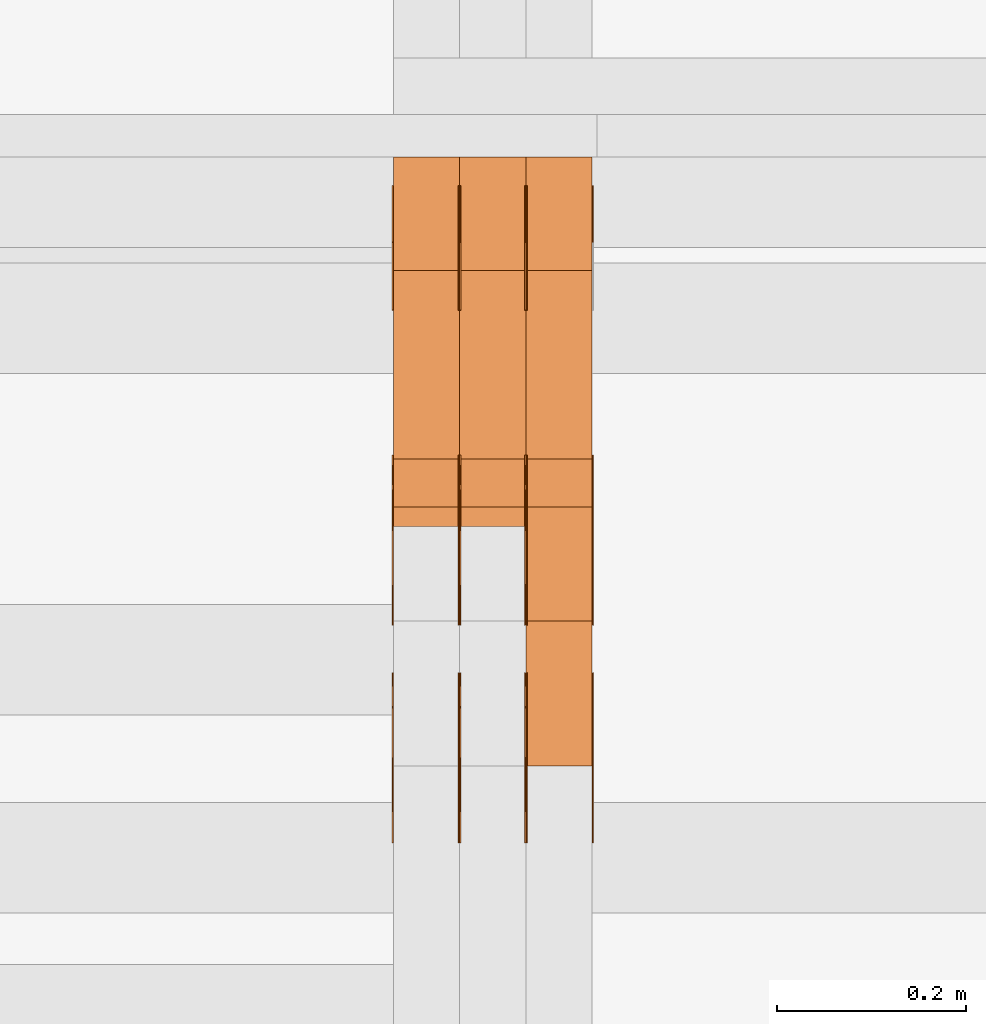
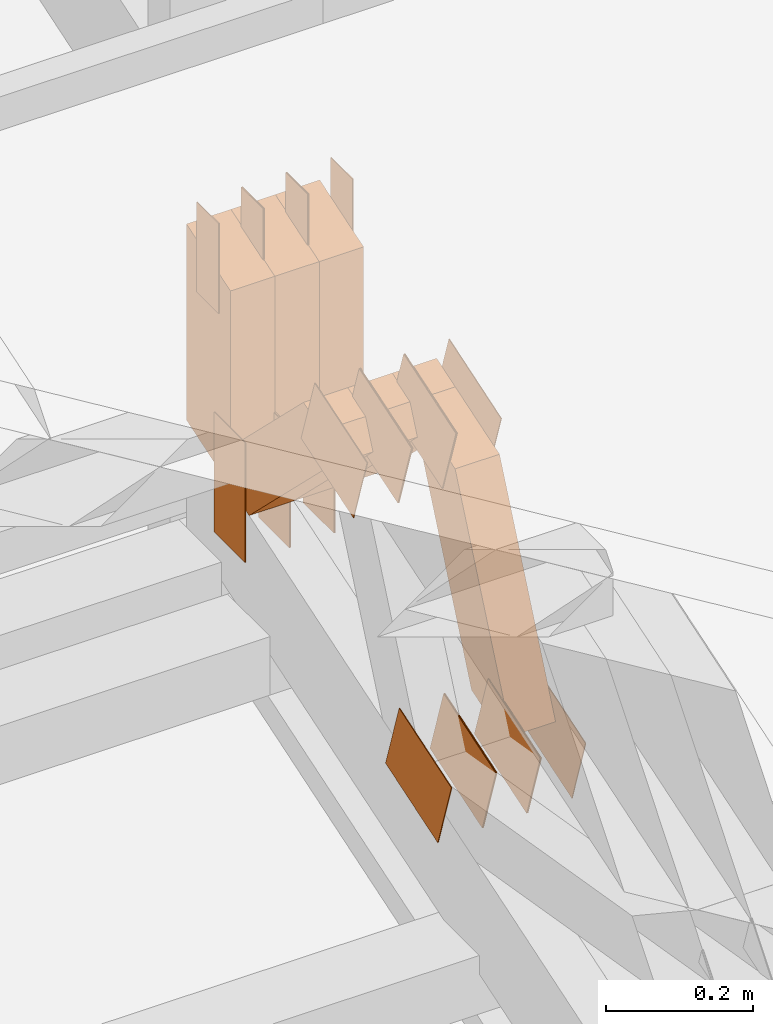
# One storey, part 78 of 385: 30 proxies.
"""IFC2X3 building model written with IfcOpenShell, lengths in millimetres."""

from ifc_helpers import new_model, entity, si_unit, converted_unit, derived_unit, direction, frame, frame_2d, origin, origin_2d_with_axis, place, context, subcontext, project, spatial, polyline, rectangle, outline, extrude, source, transform, mapped, material, type_object, type_shapes, element, save


model = new_model("IFC2X3")

# Units and contexts
model_context = context("Model", 3, precision=0.01, world=origin(), true_north=direction((6.12303176911189e-17, 1.0)))
body_context = subcontext(model_context, "Body", "Model", "MODEL_VIEW")
ifc_project = project(units=[si_unit("LENGTHUNIT", "METRE", prefix="MILLI"), si_unit("AREAUNIT", "SQUARE_METRE"), si_unit("VOLUMEUNIT", "CUBIC_METRE"), converted_unit("PLANEANGLEUNIT", "DEGREE", entity("IfcRatioMeasure", 0.0174532925199433), si_unit("PLANEANGLEUNIT", "RADIAN"), dimensions=[0, 0, 0, 0, 0, 0, 0]), si_unit("MASSUNIT", "GRAM", prefix="KILO"), derived_unit("MASSDENSITYUNIT", [(si_unit("MASSUNIT", "GRAM", prefix="KILO"), 1), (si_unit("LENGTHUNIT", "METRE"), -3)]), si_unit("TIMEUNIT", "SECOND"), si_unit("FREQUENCYUNIT", "HERTZ"), si_unit("THERMODYNAMICTEMPERATUREUNIT", "DEGREE_CELSIUS"), derived_unit("THERMALTRANSMITTANCEUNIT", [(si_unit("MASSUNIT", "GRAM", prefix="KILO"), 1), (si_unit("THERMODYNAMICTEMPERATUREUNIT", "KELVIN"), -1), (si_unit("TIMEUNIT", "SECOND"), -3)]), derived_unit("VOLUMETRICFLOWRATEUNIT", [(si_unit("LENGTHUNIT", "METRE"), 3), (si_unit("TIMEUNIT", "SECOND"), -1)]), si_unit("ELECTRICCURRENTUNIT", "AMPERE"), si_unit("ELECTRICVOLTAGEUNIT", "VOLT"), si_unit("POWERUNIT", "WATT"), si_unit("FORCEUNIT", "NEWTON", prefix="KILO"), si_unit("ILLUMINANCEUNIT", "LUX"), si_unit("LUMINOUSFLUXUNIT", "LUMEN"), si_unit("LUMINOUSINTENSITYUNIT", "CANDELA"), derived_unit("USERDEFINED", [(si_unit("MASSUNIT", "GRAM", prefix="KILO"), -1), (si_unit("LENGTHUNIT", "METRE"), -2), (si_unit("TIMEUNIT", "SECOND"), 3), (si_unit("LUMINOUSFLUXUNIT", "LUMEN"), 1)]), derived_unit("LINEARVELOCITYUNIT", [(si_unit("LENGTHUNIT", "METRE"), 1), (si_unit("TIMEUNIT", "SECOND"), -1)]), si_unit("PRESSUREUNIT", "PASCAL"), derived_unit("USERDEFINED", [(si_unit("LENGTHUNIT", "METRE"), -2), (si_unit("MASSUNIT", "GRAM", prefix="KILO"), 1), (si_unit("TIMEUNIT", "SECOND"), -2)])], contexts=[model_context])

# Site, building, storey
site_placement = place(None, origin())
site = spatial("IfcSite", under=ifc_project, at=site_placement, CompositionType="ELEMENT")
building_placement = place(site_placement, origin())
building = spatial("IfcBuilding", under=site, at=building_placement, CompositionType="ELEMENT")
storey_placement = place(building_placement, origin())
storey = spatial("IfcBuildingStorey", under=building, at=storey_placement, Name="Default", CompositionType="ELEMENT", Elevation=0.0)

# Proxies
ifc_material_1 = material(Name="IfcSurfaceStyle #71355")
building_element_proxy_type_1 = type_object("IfcBuildingElementProxyType", PredefinedType="NOTDEFINED", material=ifc_material_1)
shared_shape_1 = source(origin(), body_context, "Body", "SweptSolid", [
    extrude(rectangle(XDim=200.0, YDim=84.0, at=frame_2d((0.0, -7.105427357601e-15), x_axis=(1.0, 0.0))), frame((100.0, 42.0, 0.0), z_axis=(0.0, 0.0, 1.0), x_axis=(-1.0, 0.0, 0.0)), (0.0, 0.0, 1.0), 1.3),
])
type_shapes(building_element_proxy_type_1, [shared_shape_1])
proxy_1_placement = place(building_placement, frame((3315.0, 13702.0, 3651.4150390625), z_axis=(-1.0, 0.0, 0.0), x_axis=(0.0, 0.0, -1.0)))
element("IfcBuildingElementProxy", 1, at=proxy_1_placement, inside=storey, type_object=building_element_proxy_type_1, material=ifc_material_1, context=body_context, shape_type="MappedRepresentation", body=[
    mapped(shared_shape_1, transform((0.0, 0.0, 0.0), scale=1.0)),
])
ifc_material_2 = material(Name="IfcSurfaceStyle #71298")
building_element_proxy_type_2 = type_object("IfcBuildingElementProxyType", PredefinedType="NOTDEFINED", material=ifc_material_2)
shared_shape_2 = source(origin(), body_context, "Body", "SweptSolid", [
    extrude(rectangle(XDim=200.0, YDim=84.0, at=frame_2d((0.0, -7.105427357601e-15), x_axis=(1.0, 0.0))), frame((100.0, 42.0, 0.0), z_axis=(0.0, 0.0, 1.0), x_axis=(-1.0, 0.0, 0.0)), (0.0, 0.0, 1.0), 1.3),
])
type_shapes(building_element_proxy_type_2, [shared_shape_2])
proxy_2_placement = place(building_placement, frame((3316.29999999999, 13702.0, 3651.4150390625), z_axis=(-1.0, 0.0, 0.0), x_axis=(0.0, 0.0, -1.0)))
element("IfcBuildingElementProxy", 2, at=proxy_2_placement, inside=storey, type_object=building_element_proxy_type_2, material=ifc_material_2, context=body_context, shape_type="MappedRepresentation", body=[
    mapped(shared_shape_2, transform((0.0, 0.0, 0.0), scale=1.0)),
])
ifc_material_3 = material(Name="IfcSurfaceStyle #71241")
building_element_proxy_type_3 = type_object("IfcBuildingElementProxyType", PredefinedType="NOTDEFINED", material=ifc_material_3)
shared_shape_3 = source(origin(), body_context, "Body", "SweptSolid", [
    extrude(rectangle(XDim=200.0, YDim=84.0, at=frame_2d((0.0, -7.105427357601e-15), x_axis=(1.0, 0.0))), frame((100.0, 42.0, 0.0), z_axis=(0.0, 0.0, 1.0), x_axis=(-1.0, 0.0, 0.0)), (0.0, 0.0, 1.0), 1.29999999999998),
])
type_shapes(building_element_proxy_type_3, [shared_shape_3])
proxy_3_placement = place(building_placement, frame((3245.0, 13702.0, 3651.4150390625), z_axis=(-1.0, 0.0, 0.0), x_axis=(0.0, 0.0, -1.0)))
element("IfcBuildingElementProxy", 3, at=proxy_3_placement, inside=storey, type_object=building_element_proxy_type_3, material=ifc_material_3, context=body_context, shape_type="MappedRepresentation", body=[
    mapped(shared_shape_3, transform((0.0, 0.0, 0.0), scale=1.0)),
])
ifc_material_4 = material(Name="IfcSurfaceStyle #71184")
building_element_proxy_type_4 = type_object("IfcBuildingElementProxyType", PredefinedType="NOTDEFINED", material=ifc_material_4)
shared_shape_4 = source(origin(), body_context, "Body", "SweptSolid", [
    extrude(rectangle(XDim=200.0, YDim=84.0, at=frame_2d((0.0, -7.105427357601e-15), x_axis=(1.0, 0.0))), frame((100.0, 42.0, 0.0), z_axis=(0.0, 0.0, 1.0), x_axis=(-1.0, 0.0, 0.0)), (0.0, 0.0, 1.0), 1.29999999999998),
])
type_shapes(building_element_proxy_type_4, [shared_shape_4])
proxy_4_placement = place(building_placement, frame((3246.29999999999, 13702.0, 3651.4150390625), z_axis=(-1.0, 0.0, 0.0), x_axis=(0.0, 0.0, -1.0)))
element("IfcBuildingElementProxy", 4, at=proxy_4_placement, inside=storey, type_object=building_element_proxy_type_4, material=ifc_material_4, context=body_context, shape_type="MappedRepresentation", body=[
    mapped(shared_shape_4, transform((0.0, 0.0, 0.0), scale=1.0)),
])
ifc_material_5 = material(Name="IfcSurfaceStyle #71127")
building_element_proxy_type_5 = type_object("IfcBuildingElementProxyType", PredefinedType="NOTDEFINED", material=ifc_material_5)
shared_shape_5 = source(origin(), body_context, "Body", "SweptSolid", [
    extrude(rectangle(XDim=200.0, YDim=84.0, at=frame_2d((0.0, -7.105427357601e-15), x_axis=(1.0, 0.0))), frame((100.0, 42.0, 0.0), z_axis=(0.0, 0.0, 1.0), x_axis=(-1.0, 0.0, 0.0)), (0.0, 0.0, 1.0), 1.29999999999999),
])
type_shapes(building_element_proxy_type_5, [shared_shape_5])
proxy_5_placement = place(building_placement, frame((3175.0, 13702.0, 3651.4150390625), z_axis=(-1.0, 0.0, 0.0), x_axis=(0.0, 0.0, -1.0)))
element("IfcBuildingElementProxy", 5, at=proxy_5_placement, inside=storey, type_object=building_element_proxy_type_5, material=ifc_material_5, context=body_context, shape_type="MappedRepresentation", body=[
    mapped(shared_shape_5, transform((0.0, 0.0, 0.0), scale=1.0)),
])
ifc_material_6 = material(Name="IfcSurfaceStyle #71070")
building_element_proxy_type_6 = type_object("IfcBuildingElementProxyType", PredefinedType="NOTDEFINED", material=ifc_material_6)
shared_shape_6 = source(origin(), body_context, "Body", "SweptSolid", [
    extrude(outline(polyline([(-75.0003398116828, -59.9998507501386), (75.0003249421766, -59.9998507501386), (75.0003398116837, 59.9998507501387), (-75.0003249421775, 59.9998507501387), (-75.0003398116828, -59.9998507501386)])), frame((75.0003398116837, 60.0000773549637, 0.0), z_axis=(0.0, 0.0, 1.0), x_axis=(-1.0, 0.0, 0.0)), (0.0, 0.0, 1.0), 1.3),
])
type_shapes(building_element_proxy_type_6, [shared_shape_6])
proxy_6_placement = place(building_placement, frame((3386.29999999999, 13054.73046875, 3417.8388671875), z_axis=(-1.0, 0.0, 0.0), x_axis=(0.0, 0.951056516295124, 0.309016994375039)))
element("IfcBuildingElementProxy", 6, at=proxy_6_placement, inside=storey, type_object=building_element_proxy_type_6, material=ifc_material_6, context=body_context, shape_type="MappedRepresentation", body=[
    mapped(shared_shape_6, transform((0.0, 0.0, 0.0), scale=1.0)),
])
ifc_material_7 = material(Name="IfcSurfaceStyle #71013")
building_element_proxy_type_7 = type_object("IfcBuildingElementProxyType", PredefinedType="NOTDEFINED", material=ifc_material_7)
shared_shape_7 = source(origin(), body_context, "Body", "SweptSolid", [
    extrude(outline(polyline([(-75.0003398116828, -59.9998507501386), (75.0003249421766, -59.9998507501386), (75.0003398116837, 59.9998507501387), (-75.0003249421775, 59.9998507501387), (-75.0003398116828, -59.9998507501386)])), frame((75.0003398116837, 60.0000773549637, 0.0), z_axis=(0.0, 0.0, 1.0), x_axis=(-1.0, 0.0, 0.0)), (0.0, 0.0, 1.0), 1.3),
])
type_shapes(building_element_proxy_type_7, [shared_shape_7])
proxy_7_placement = place(building_placement, frame((3315.0, 13054.73046875, 3417.8388671875), z_axis=(-1.0, 0.0, 0.0), x_axis=(0.0, 0.951056516295124, 0.309016994375039)))
element("IfcBuildingElementProxy", 7, at=proxy_7_placement, inside=storey, type_object=building_element_proxy_type_7, material=ifc_material_7, context=body_context, shape_type="MappedRepresentation", body=[
    mapped(shared_shape_7, transform((0.0, 0.0, 0.0), scale=1.0)),
])
ifc_material_8 = material(Name="IfcSurfaceStyle #70956")
building_element_proxy_type_8 = type_object("IfcBuildingElementProxyType", PredefinedType="NOTDEFINED", material=ifc_material_8)
shared_shape_8 = source(origin(), body_context, "Body", "SweptSolid", [
    extrude(outline(polyline([(-75.0003398116828, -59.9998507501386), (75.0003249421766, -59.9998507501386), (75.0003398116837, 59.9998507501387), (-75.0003249421775, 59.9998507501387), (-75.0003398116828, -59.9998507501386)])), frame((75.0003398116837, 60.0000773549637, 0.0), z_axis=(0.0, 0.0, 1.0), x_axis=(-1.0, 0.0, 0.0)), (0.0, 0.0, 1.0), 1.3),
])
type_shapes(building_element_proxy_type_8, [shared_shape_8])
proxy_8_placement = place(building_placement, frame((3316.29999999999, 13054.73046875, 3417.8388671875), z_axis=(-1.0, 0.0, 0.0), x_axis=(0.0, 0.951056516295124, 0.309016994375039)))
element("IfcBuildingElementProxy", 8, at=proxy_8_placement, inside=storey, type_object=building_element_proxy_type_8, material=ifc_material_8, context=body_context, shape_type="MappedRepresentation", body=[
    mapped(shared_shape_8, transform((0.0, 0.0, 0.0), scale=1.0)),
])
ifc_material_9 = material(Name="IfcSurfaceStyle #70899")
building_element_proxy_type_9 = type_object("IfcBuildingElementProxyType", PredefinedType="NOTDEFINED", material=ifc_material_9)
shared_shape_9 = source(origin(), body_context, "Body", "SweptSolid", [
    extrude(outline(polyline([(-75.0003398116828, -59.9998507501386), (75.0003249421766, -59.9998507501386), (75.0003398116837, 59.9998507501387), (-75.0003249421775, 59.9998507501387), (-75.0003398116828, -59.9998507501386)])), frame((75.0003398116837, 60.0000773549637, 0.0), z_axis=(0.0, 0.0, 1.0), x_axis=(-1.0, 0.0, 0.0)), (0.0, 0.0, 1.0), 1.29999999999999),
])
type_shapes(building_element_proxy_type_9, [shared_shape_9])
proxy_9_placement = place(building_placement, frame((3245.0, 13054.73046875, 3417.8388671875), z_axis=(-1.0, 0.0, 0.0), x_axis=(0.0, 0.951056516295124, 0.309016994375039)))
element("IfcBuildingElementProxy", 9, at=proxy_9_placement, inside=storey, type_object=building_element_proxy_type_9, material=ifc_material_9, context=body_context, shape_type="MappedRepresentation", body=[
    mapped(shared_shape_9, transform((0.0, 0.0, 0.0), scale=1.0)),
])
ifc_material_10 = material(Name="IfcSurfaceStyle #70842")
building_element_proxy_type_10 = type_object("IfcBuildingElementProxyType", PredefinedType="NOTDEFINED", material=ifc_material_10)
shared_shape_10 = source(origin(), body_context, "Body", "SweptSolid", [
    extrude(outline(polyline([(-75.0003398116828, -59.9998507501386), (75.0003249421766, -59.9998507501386), (75.0003398116837, 59.9998507501387), (-75.0003249421775, 59.9998507501387), (-75.0003398116828, -59.9998507501386)])), frame((75.0003398116837, 60.0000773549637, 0.0), z_axis=(0.0, 0.0, 1.0), x_axis=(-1.0, 0.0, 0.0)), (0.0, 0.0, 1.0), 1.29999999999999),
])
type_shapes(building_element_proxy_type_10, [shared_shape_10])
proxy_10_placement = place(building_placement, frame((3246.29999999999, 13054.73046875, 3417.8388671875), z_axis=(-1.0, 0.0, 0.0), x_axis=(0.0, 0.951056516295124, 0.309016994375039)))
element("IfcBuildingElementProxy", 10, at=proxy_10_placement, inside=storey, type_object=building_element_proxy_type_10, material=ifc_material_10, context=body_context, shape_type="MappedRepresentation", body=[
    mapped(shared_shape_10, transform((0.0, 0.0, 0.0), scale=1.0)),
])
ifc_material_11 = material(Name="IfcSurfaceStyle #70785")
building_element_proxy_type_11 = type_object("IfcBuildingElementProxyType", PredefinedType="NOTDEFINED", material=ifc_material_11)
shared_shape_11 = source(origin(), body_context, "Body", "SweptSolid", [
    extrude(outline(polyline([(-75.0003398116828, -59.9998507501386), (75.0003249421766, -59.9998507501386), (75.0003398116837, 59.9998507501387), (-75.0003249421775, 59.9998507501387), (-75.0003398116828, -59.9998507501386)])), frame((75.0003398116837, 60.0000773549637, 0.0), z_axis=(0.0, 0.0, 1.0), x_axis=(-1.0, 0.0, 0.0)), (0.0, 0.0, 1.0), 1.29999999999999),
])
type_shapes(building_element_proxy_type_11, [shared_shape_11])
proxy_11_placement = place(building_placement, frame((3175.0, 13054.73046875, 3417.8388671875), z_axis=(-1.0, 0.0, 0.0), x_axis=(0.0, 0.951056516295124, 0.309016994375039)))
element("IfcBuildingElementProxy", 11, at=proxy_11_placement, inside=storey, type_object=building_element_proxy_type_11, material=ifc_material_11, context=body_context, shape_type="MappedRepresentation", body=[
    mapped(shared_shape_11, transform((0.0, 0.0, 0.0), scale=1.0)),
])
ifc_material_12 = material(Name="IfcSurfaceStyle #63204")
building_element_proxy_type_12 = type_object("IfcBuildingElementProxyType", PredefinedType="NOTDEFINED", material=ifc_material_12)
shared_shape_12 = source(origin(), body_context, "Body", "SweptSolid", [
    extrude(outline(polyline([(-74.999875428623, -60.0000016373506), (74.9998605591059, -60.0000016373506), (74.9998754286239, 60.0000016373506), (-74.9998605591068, 60.0000016373506), (-74.999875428623, -60.0000016373506)])), frame((75.0002691827262, 60.0000190504561, 0.0), z_axis=(0.0, 0.0, 1.0), x_axis=(-1.0, 0.0, 0.0)), (0.0, 0.0, 1.0), 1.3),
])
type_shapes(building_element_proxy_type_12, [shared_shape_12])
proxy_12_placement = place(building_placement, frame((3386.29999999999, 13285.0865109705, 3819.37496637467), z_axis=(-1.0, 0.0, 0.0), x_axis=(0.0, 0.951056516295154, 0.309016994374948)))
element("IfcBuildingElementProxy", 12, at=proxy_12_placement, inside=storey, type_object=building_element_proxy_type_12, material=ifc_material_12, context=body_context, shape_type="MappedRepresentation", body=[
    mapped(shared_shape_12, transform((0.0, 0.0, 0.0), scale=1.0)),
])
ifc_material_13 = material(Name="IfcSurfaceStyle #63147")
building_element_proxy_type_13 = type_object("IfcBuildingElementProxyType", PredefinedType="NOTDEFINED", material=ifc_material_13)
shared_shape_13 = source(origin(), body_context, "Body", "SweptSolid", [
    extrude(outline(polyline([(-74.999875428623, -60.0000016373506), (74.9998605591059, -60.0000016373506), (74.9998754286239, 60.0000016373506), (-74.9998605591068, 60.0000016373506), (-74.999875428623, -60.0000016373506)])), frame((75.0002691827262, 60.0000190504561, 0.0), z_axis=(0.0, 0.0, 1.0), x_axis=(-1.0, 0.0, 0.0)), (0.0, 0.0, 1.0), 1.3),
])
type_shapes(building_element_proxy_type_13, [shared_shape_13])
proxy_13_placement = place(building_placement, frame((3315.0, 13285.0865109705, 3819.37496637467), z_axis=(-1.0, 0.0, 0.0), x_axis=(0.0, 0.951056516295154, 0.309016994374948)))
element("IfcBuildingElementProxy", 13, at=proxy_13_placement, inside=storey, type_object=building_element_proxy_type_13, material=ifc_material_13, context=body_context, shape_type="MappedRepresentation", body=[
    mapped(shared_shape_13, transform((0.0, 0.0, 0.0), scale=1.0)),
])
ifc_material_14 = material(Name="IfcSurfaceStyle #63090")
building_element_proxy_type_14 = type_object("IfcBuildingElementProxyType", PredefinedType="NOTDEFINED", material=ifc_material_14)
shared_shape_14 = source(origin(), body_context, "Body", "SweptSolid", [
    extrude(outline(polyline([(-74.999875428623, -60.0000016373506), (74.9998605591059, -60.0000016373506), (74.9998754286239, 60.0000016373506), (-74.9998605591068, 60.0000016373506), (-74.999875428623, -60.0000016373506)])), frame((75.0002691827262, 60.0000190504561, 0.0), z_axis=(0.0, 0.0, 1.0), x_axis=(-1.0, 0.0, 0.0)), (0.0, 0.0, 1.0), 1.3),
])
type_shapes(building_element_proxy_type_14, [shared_shape_14])
proxy_14_placement = place(building_placement, frame((3316.29999999999, 13285.0865109705, 3819.37496637467), z_axis=(-1.0, 0.0, 0.0), x_axis=(0.0, 0.951056516295154, 0.309016994374948)))
element("IfcBuildingElementProxy", 14, at=proxy_14_placement, inside=storey, type_object=building_element_proxy_type_14, material=ifc_material_14, context=body_context, shape_type="MappedRepresentation", body=[
    mapped(shared_shape_14, transform((0.0, 0.0, 0.0), scale=1.0)),
])
ifc_material_15 = material(Name="IfcSurfaceStyle #63033")
building_element_proxy_type_15 = type_object("IfcBuildingElementProxyType", PredefinedType="NOTDEFINED", material=ifc_material_15)
shared_shape_15 = source(origin(), body_context, "Body", "SweptSolid", [
    extrude(outline(polyline([(-74.999875428623, -60.0000016373506), (74.9998605591059, -60.0000016373506), (74.9998754286239, 60.0000016373506), (-74.9998605591068, 60.0000016373506), (-74.999875428623, -60.0000016373506)])), frame((75.0002691827262, 60.0000190504561, 0.0), z_axis=(0.0, 0.0, 1.0), x_axis=(-1.0, 0.0, 0.0)), (0.0, 0.0, 1.0), 1.29999999999999),
])
type_shapes(building_element_proxy_type_15, [shared_shape_15])
proxy_15_placement = place(building_placement, frame((3245.0, 13285.0865109705, 3819.37496637467), z_axis=(-1.0, 0.0, 0.0), x_axis=(0.0, 0.951056516295154, 0.309016994374948)))
element("IfcBuildingElementProxy", 15, at=proxy_15_placement, inside=storey, type_object=building_element_proxy_type_15, material=ifc_material_15, context=body_context, shape_type="MappedRepresentation", body=[
    mapped(shared_shape_15, transform((0.0, 0.0, 0.0), scale=1.0)),
])
ifc_material_16 = material(Name="IfcSurfaceStyle #62976")
building_element_proxy_type_16 = type_object("IfcBuildingElementProxyType", PredefinedType="NOTDEFINED", material=ifc_material_16)
shared_shape_16 = source(origin(), body_context, "Body", "SweptSolid", [
    extrude(outline(polyline([(-74.999875428623, -60.0000016373506), (74.9998605591059, -60.0000016373506), (74.9998754286239, 60.0000016373506), (-74.9998605591068, 60.0000016373506), (-74.999875428623, -60.0000016373506)])), frame((75.0002691827262, 60.0000190504561, 0.0), z_axis=(0.0, 0.0, 1.0), x_axis=(-1.0, 0.0, 0.0)), (0.0, 0.0, 1.0), 1.29999999999999),
])
type_shapes(building_element_proxy_type_16, [shared_shape_16])
proxy_16_placement = place(building_placement, frame((3246.29999999999, 13285.0865109705, 3819.37496637467), z_axis=(-1.0, 0.0, 0.0), x_axis=(0.0, 0.951056516295154, 0.309016994374948)))
element("IfcBuildingElementProxy", 16, at=proxy_16_placement, inside=storey, type_object=building_element_proxy_type_16, material=ifc_material_16, context=body_context, shape_type="MappedRepresentation", body=[
    mapped(shared_shape_16, transform((0.0, 0.0, 0.0), scale=1.0)),
])
ifc_material_17 = material(Name="IfcSurfaceStyle #62919")
building_element_proxy_type_17 = type_object("IfcBuildingElementProxyType", PredefinedType="NOTDEFINED", material=ifc_material_17)
shared_shape_17 = source(origin(), body_context, "Body", "SweptSolid", [
    extrude(outline(polyline([(-74.999875428623, -60.0000016373506), (74.9998605591059, -60.0000016373506), (74.9998754286239, 60.0000016373506), (-74.9998605591068, 60.0000016373506), (-74.999875428623, -60.0000016373506)])), frame((75.0002691827262, 60.0000190504561, 0.0), z_axis=(0.0, 0.0, 1.0), x_axis=(-1.0, 0.0, 0.0)), (0.0, 0.0, 1.0), 1.29999999999999),
])
type_shapes(building_element_proxy_type_17, [shared_shape_17])
proxy_17_placement = place(building_placement, frame((3175.0, 13285.0865109705, 3819.37496637467), z_axis=(-1.0, 0.0, 0.0), x_axis=(0.0, 0.951056516295154, 0.309016994374948)))
element("IfcBuildingElementProxy", 17, at=proxy_17_placement, inside=storey, type_object=building_element_proxy_type_17, material=ifc_material_17, context=body_context, shape_type="MappedRepresentation", body=[
    mapped(shared_shape_17, transform((0.0, 0.0, 0.0), scale=1.0)),
])
ifc_material_18 = material(Name="IfcSurfaceStyle #62520")
building_element_proxy_type_18 = type_object("IfcBuildingElementProxyType", PredefinedType="NOTDEFINED", material=ifc_material_18)
shared_shape_18 = source(origin(), body_context, "Body", "SweptSolid", [
    extrude(rectangle(XDim=150.0, YDim=60.0, at=origin_2d_with_axis()), frame((75.0000705696166, 30.0, 0.0), z_axis=(0.0, 0.0, 1.0), x_axis=(-1.0, 0.0, 0.0)), (0.0, 0.0, 1.0), 1.3),
])
type_shapes(building_element_proxy_type_18, [shared_shape_18])
proxy_18_placement = place(building_placement, frame((3386.29999999999, 13750.0, 3972.59919166337), z_axis=(-1.0, 0.0, 0.0), x_axis=(0.0, 0.0, -1.0)))
element("IfcBuildingElementProxy", 18, at=proxy_18_placement, inside=storey, type_object=building_element_proxy_type_18, material=ifc_material_18, context=body_context, shape_type="MappedRepresentation", body=[
    mapped(shared_shape_18, transform((0.0, 0.0, 0.0), scale=1.0)),
])
ifc_material_19 = material(Name="IfcSurfaceStyle #62463")
building_element_proxy_type_19 = type_object("IfcBuildingElementProxyType", PredefinedType="NOTDEFINED", material=ifc_material_19)
shared_shape_19 = source(origin(), body_context, "Body", "SweptSolid", [
    extrude(rectangle(XDim=150.0, YDim=60.0, at=origin_2d_with_axis()), frame((75.0000705696166, 30.0, 0.0), z_axis=(0.0, 0.0, 1.0), x_axis=(-1.0, 0.0, 0.0)), (0.0, 0.0, 1.0), 1.3),
])
type_shapes(building_element_proxy_type_19, [shared_shape_19])
proxy_19_placement = place(building_placement, frame((3315.0, 13750.0, 3972.59919166337), z_axis=(-1.0, 0.0, 0.0), x_axis=(0.0, 0.0, -1.0)))
element("IfcBuildingElementProxy", 19, at=proxy_19_placement, inside=storey, type_object=building_element_proxy_type_19, material=ifc_material_19, context=body_context, shape_type="MappedRepresentation", body=[
    mapped(shared_shape_19, transform((0.0, 0.0, 0.0), scale=1.0)),
])
ifc_material_20 = material(Name="IfcSurfaceStyle #62406")
building_element_proxy_type_20 = type_object("IfcBuildingElementProxyType", PredefinedType="NOTDEFINED", material=ifc_material_20)
shared_shape_20 = source(origin(), body_context, "Body", "SweptSolid", [
    extrude(rectangle(XDim=150.0, YDim=60.0, at=origin_2d_with_axis()), frame((75.0000705696166, 30.0, 0.0), z_axis=(0.0, 0.0, 1.0), x_axis=(-1.0, 0.0, 0.0)), (0.0, 0.0, 1.0), 1.3),
])
type_shapes(building_element_proxy_type_20, [shared_shape_20])
proxy_20_placement = place(building_placement, frame((3316.29999999999, 13750.0, 3972.59919166337), z_axis=(-1.0, 0.0, 0.0), x_axis=(0.0, 0.0, -1.0)))
element("IfcBuildingElementProxy", 20, at=proxy_20_placement, inside=storey, type_object=building_element_proxy_type_20, material=ifc_material_20, context=body_context, shape_type="MappedRepresentation", body=[
    mapped(shared_shape_20, transform((0.0, 0.0, 0.0), scale=1.0)),
])
ifc_material_21 = material(Name="IfcSurfaceStyle #62349")
building_element_proxy_type_21 = type_object("IfcBuildingElementProxyType", PredefinedType="NOTDEFINED", material=ifc_material_21)
shared_shape_21 = source(origin(), body_context, "Body", "SweptSolid", [
    extrude(rectangle(XDim=150.0, YDim=60.0, at=origin_2d_with_axis()), frame((75.0000705696166, 30.0, 0.0), z_axis=(0.0, 0.0, 1.0), x_axis=(-1.0, 0.0, 0.0)), (0.0, 0.0, 1.0), 1.29999999999999),
])
type_shapes(building_element_proxy_type_21, [shared_shape_21])
proxy_21_placement = place(building_placement, frame((3245.0, 13750.0, 3972.59919166337), z_axis=(-1.0, 0.0, 0.0), x_axis=(0.0, 0.0, -1.0)))
element("IfcBuildingElementProxy", 21, at=proxy_21_placement, inside=storey, type_object=building_element_proxy_type_21, material=ifc_material_21, context=body_context, shape_type="MappedRepresentation", body=[
    mapped(shared_shape_21, transform((0.0, 0.0, 0.0), scale=1.0)),
])
ifc_material_22 = material(Name="IfcSurfaceStyle #62292")
building_element_proxy_type_22 = type_object("IfcBuildingElementProxyType", PredefinedType="NOTDEFINED", material=ifc_material_22)
shared_shape_22 = source(origin(), body_context, "Body", "SweptSolid", [
    extrude(rectangle(XDim=150.0, YDim=60.0, at=origin_2d_with_axis()), frame((75.0000705696166, 30.0, 0.0), z_axis=(0.0, 0.0, 1.0), x_axis=(-1.0, 0.0, 0.0)), (0.0, 0.0, 1.0), 1.29999999999999),
])
type_shapes(building_element_proxy_type_22, [shared_shape_22])
proxy_22_placement = place(building_placement, frame((3246.29999999999, 13750.0, 3972.59919166337), z_axis=(-1.0, 0.0, 0.0), x_axis=(0.0, 0.0, -1.0)))
element("IfcBuildingElementProxy", 22, at=proxy_22_placement, inside=storey, type_object=building_element_proxy_type_22, material=ifc_material_22, context=body_context, shape_type="MappedRepresentation", body=[
    mapped(shared_shape_22, transform((0.0, 0.0, 0.0), scale=1.0)),
])
ifc_material_23 = material(Name="IfcSurfaceStyle #62235")
building_element_proxy_type_23 = type_object("IfcBuildingElementProxyType", PredefinedType="NOTDEFINED", material=ifc_material_23)
shared_shape_23 = source(origin(), body_context, "Body", "SweptSolid", [
    extrude(rectangle(XDim=150.0, YDim=60.0, at=origin_2d_with_axis()), frame((75.0000705696166, 30.0, 0.0), z_axis=(0.0, 0.0, 1.0), x_axis=(-1.0, 0.0, 0.0)), (0.0, 0.0, 1.0), 1.29999999999999),
])
type_shapes(building_element_proxy_type_23, [shared_shape_23])
proxy_23_placement = place(building_placement, frame((3175.0, 13750.0, 3972.59919166337), z_axis=(-1.0, 0.0, 0.0), x_axis=(0.0, 0.0, -1.0)))
element("IfcBuildingElementProxy", 23, at=proxy_23_placement, inside=storey, type_object=building_element_proxy_type_23, material=ifc_material_23, context=body_context, shape_type="MappedRepresentation", body=[
    mapped(shared_shape_23, transform((0.0, 0.0, 0.0), scale=1.0)),
])
ifc_material_24 = material(Name="IfcSurfaceStyle #53034")
building_element_proxy_type_24 = type_object("IfcBuildingElementProxyType", Name="T1-W49 53032", PredefinedType="NOTDEFINED", material=ifc_material_24)
shared_shape_24 = source(origin(), body_context, "Body", "SweptSolid", [
    extrude(outline(polyline([(-155.175867306415, -47.4997478409253), (152.310664695054, -47.4997478409253), (170.496756790954, -6.14570120142345e-05), (145.70957993751, 47.4998092979374), (-133.37808995724, 47.4998092979373), (-179.963044159863, -6.14570120298391e-05), (-155.175867306415, -47.4997478409253)])), frame((170.496756790954, 47.5001152140455, 0.0), z_axis=(0.0, 0.0, 1.0), x_axis=(-1.0, 0.0, 0.0)), (0.0, 0.0, 1.0), 70.0),
])
type_shapes(building_element_proxy_type_24, [shared_shape_24])
proxy_24_placement = place(building_placement, frame((3385.0, 13443.048524104, 3830.71841973934), z_axis=(-1.0, 0.0, 0.0), x_axis=(0.0, 0.713950095632063, -0.700196587357413)))
element("IfcBuildingElementProxy", 24, at=proxy_24_placement, inside=storey, type_object=building_element_proxy_type_24, material=ifc_material_24, Name="T1-W49", context=body_context, shape_type="MappedRepresentation", body=[
    mapped(shared_shape_24, transform((0.0, 0.0, 0.0), scale=1.0)),
])
ifc_material_25 = material(Name="IfcSurfaceStyle #52959")
building_element_proxy_type_25 = type_object("IfcBuildingElementProxyType", Name="T1-W49 52957", PredefinedType="NOTDEFINED", material=ifc_material_25)
shared_shape_25 = source(origin(), body_context, "Body", "SweptSolid", [
    extrude(outline(polyline([(-155.175867306415, -47.4997478409253), (152.310664695054, -47.4997478409253), (170.496756790954, -6.14570120142345e-05), (145.70957993751, 47.4998092979374), (-133.37808995724, 47.4998092979373), (-179.963044159863, -6.14570120298391e-05), (-155.175867306415, -47.4997478409253)])), frame((170.496756790954, 47.5001152140455, 0.0), z_axis=(0.0, 0.0, 1.0), x_axis=(-1.0, 0.0, 0.0)), (0.0, 0.0, 1.0), 70.0),
])
type_shapes(building_element_proxy_type_25, [shared_shape_25])
proxy_25_placement = place(building_placement, frame((3315.0, 13443.048524104, 3830.71841973934), z_axis=(-1.0, 0.0, 0.0), x_axis=(0.0, 0.713950095632063, -0.700196587357413)))
element("IfcBuildingElementProxy", 25, at=proxy_25_placement, inside=storey, type_object=building_element_proxy_type_25, material=ifc_material_25, Name="T1-W49", context=body_context, shape_type="MappedRepresentation", body=[
    mapped(shared_shape_25, transform((0.0, 0.0, 0.0), scale=1.0)),
])
ifc_material_26 = material(Name="IfcSurfaceStyle #52884")
building_element_proxy_type_26 = type_object("IfcBuildingElementProxyType", Name="T1-W49 52882", PredefinedType="NOTDEFINED", material=ifc_material_26)
shared_shape_26 = source(origin(), body_context, "Body", "SweptSolid", [
    extrude(outline(polyline([(-155.175867306415, -47.4997478409253), (152.310664695054, -47.4997478409253), (170.496756790954, -6.14570120142345e-05), (145.70957993751, 47.4998092979374), (-133.37808995724, 47.4998092979373), (-179.963044159863, -6.14570120298391e-05), (-155.175867306415, -47.4997478409253)])), frame((170.496756790954, 47.5001152140455, 0.0), z_axis=(0.0, 0.0, 1.0), x_axis=(-1.0, 0.0, 0.0)), (0.0, 0.0, 1.0), 70.0),
])
type_shapes(building_element_proxy_type_26, [shared_shape_26])
proxy_26_placement = place(building_placement, frame((3245.0, 13443.048524104, 3830.71841973934), z_axis=(-1.0, 0.0, 0.0), x_axis=(0.0, 0.713950095632063, -0.700196587357413)))
element("IfcBuildingElementProxy", 26, at=proxy_26_placement, inside=storey, type_object=building_element_proxy_type_26, material=ifc_material_26, Name="T1-W49", context=body_context, shape_type="MappedRepresentation", body=[
    mapped(shared_shape_26, transform((0.0, 0.0, 0.0), scale=1.0)),
])
ifc_material_27 = material(Name="IfcSurfaceStyle #52584")
building_element_proxy_type_27 = type_object("IfcBuildingElementProxyType", Name="T1-W1 52582", PredefinedType="NOTDEFINED", material=ifc_material_27)
shared_shape_27 = source(origin(), body_context, "Body", "SweptSolid", [
    extrude(outline(polyline([(-182.839782714844, -60.0), (143.849426269531, -60.0), (182.839660644531, 60.0), (-143.849304199219, 60.0), (-182.839782714844, -60.0)])), frame((182.839674685549, 60.0, 0.0), z_axis=(0.0, 0.0, 1.0), x_axis=(-1.0, 0.0, 0.0)), (0.0, 0.0, 1.0), 70.0),
])
type_shapes(building_element_proxy_type_27, [shared_shape_27])
proxy_27_placement = place(building_placement, frame((3385.0, 13660.0, 3551.41502502148), z_axis=(-1.0, 0.0, 0.0), x_axis=(0.0, 0.0, 1.0)))
element("IfcBuildingElementProxy", 27, at=proxy_27_placement, inside=storey, type_object=building_element_proxy_type_27, material=ifc_material_27, Name="T1-W1", context=body_context, shape_type="MappedRepresentation", body=[
    mapped(shared_shape_27, transform((0.0, 0.0, 0.0), scale=1.0)),
])
ifc_material_28 = material(Name="IfcSurfaceStyle #52527")
building_element_proxy_type_28 = type_object("IfcBuildingElementProxyType", Name="T1-W1 52525", PredefinedType="NOTDEFINED", material=ifc_material_28)
shared_shape_28 = source(origin(), body_context, "Body", "SweptSolid", [
    extrude(outline(polyline([(-182.839782714844, -60.0), (143.849426269531, -60.0), (182.839660644531, 60.0), (-143.849304199219, 60.0), (-182.839782714844, -60.0)])), frame((182.839674685549, 60.0, 0.0), z_axis=(0.0, 0.0, 1.0), x_axis=(-1.0, 0.0, 0.0)), (0.0, 0.0, 1.0), 70.0),
])
type_shapes(building_element_proxy_type_28, [shared_shape_28])
proxy_28_placement = place(building_placement, frame((3315.0, 13660.0, 3551.41502502148), z_axis=(-1.0, 0.0, 0.0), x_axis=(0.0, 0.0, 1.0)))
element("IfcBuildingElementProxy", 28, at=proxy_28_placement, inside=storey, type_object=building_element_proxy_type_28, material=ifc_material_28, Name="T1-W1", context=body_context, shape_type="MappedRepresentation", body=[
    mapped(shared_shape_28, transform((0.0, 0.0, 0.0), scale=1.0)),
])
ifc_material_29 = material(Name="IfcSurfaceStyle #52470")
building_element_proxy_type_29 = type_object("IfcBuildingElementProxyType", Name="T1-W1 52468", PredefinedType="NOTDEFINED", material=ifc_material_29)
shared_shape_29 = source(origin(), body_context, "Body", "SweptSolid", [
    extrude(outline(polyline([(-182.839782714844, -60.0), (143.849426269531, -60.0), (182.839660644531, 60.0), (-143.849304199219, 60.0), (-182.839782714844, -60.0)])), frame((182.839674685549, 60.0, 0.0), z_axis=(0.0, 0.0, 1.0), x_axis=(-1.0, 0.0, 0.0)), (0.0, 0.0, 1.0), 70.0),
])
type_shapes(building_element_proxy_type_29, [shared_shape_29])
proxy_29_placement = place(building_placement, frame((3245.0, 13660.0, 3551.41502502148), z_axis=(-1.0, 0.0, 0.0), x_axis=(0.0, 0.0, 1.0)))
element("IfcBuildingElementProxy", 29, at=proxy_29_placement, inside=storey, type_object=building_element_proxy_type_29, material=ifc_material_29, Name="T1-W1", context=body_context, shape_type="MappedRepresentation", body=[
    mapped(shared_shape_29, transform((0.0, 0.0, 0.0), scale=1.0)),
])
ifc_material_30 = material(Name="IfcSurfaceStyle #52044")
building_element_proxy_type_30 = type_object("IfcBuildingElementProxyType", Name="T1-W42 52042", PredefinedType="NOTDEFINED", material=ifc_material_30)
shared_shape_30 = source(origin(), body_context, "Body", "SweptSolid", [
    extrude(outline(polyline([(-284.837590197601, -47.4997543607933), (129.95880168156, -47.4997543607933), (171.972324990451, 0.000162623346093338), (183.717007105413, 47.4996730491203), (-200.810543579822, 47.4996730491203), (-284.837590197601, -47.4997543607933)])), frame((183.717155718752, 47.4999821655365, 0.0), z_axis=(0.0, 0.0, 1.0), x_axis=(-1.0, 0.0, 0.0)), (0.0, 0.0, 1.0), 70.0),
])
type_shapes(building_element_proxy_type_30, [shared_shape_30])
proxy_30_placement = place(building_placement, frame((3385.0, 13135.8834463264, 3404.958483022), z_axis=(-1.0, 0.0, 0.0), x_axis=(0.0, 0.398630596470292, 0.917111578575769)))
element("IfcBuildingElementProxy", 30, at=proxy_30_placement, inside=storey, type_object=building_element_proxy_type_30, material=ifc_material_30, Name="T1-W42", context=body_context, shape_type="MappedRepresentation", body=[
    mapped(shared_shape_30, transform((0.0, 0.0, 0.0), scale=1.0)),
])

save(model, "model.ifc")
